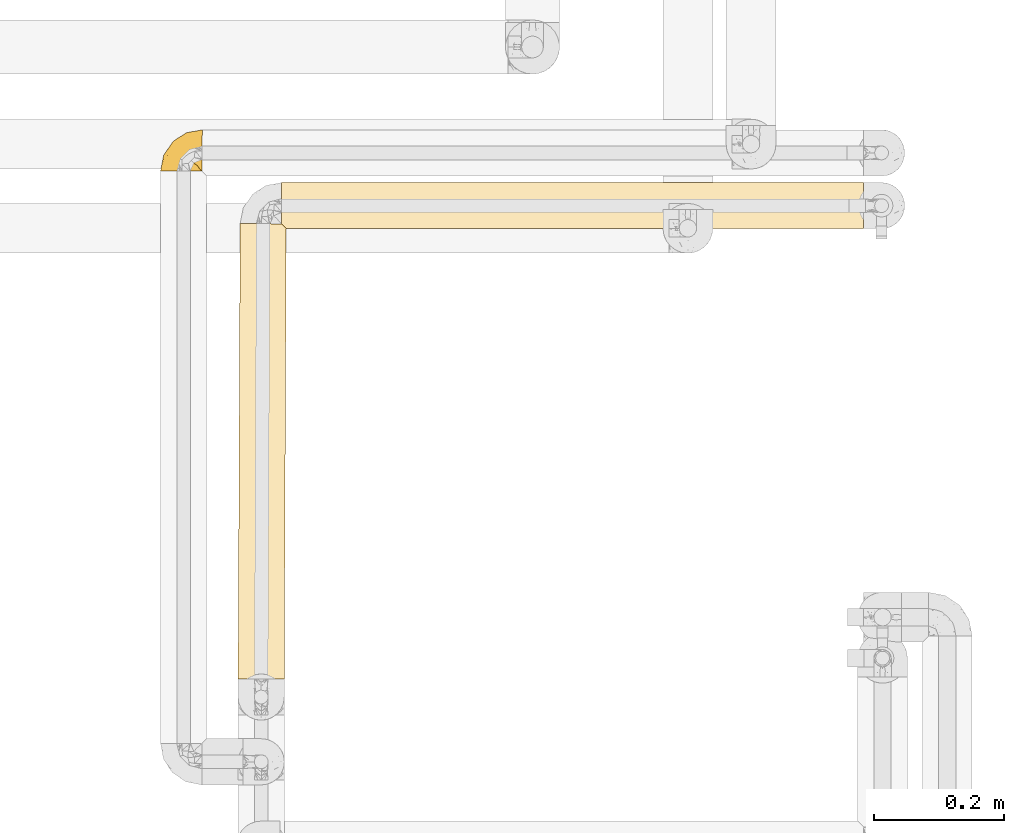
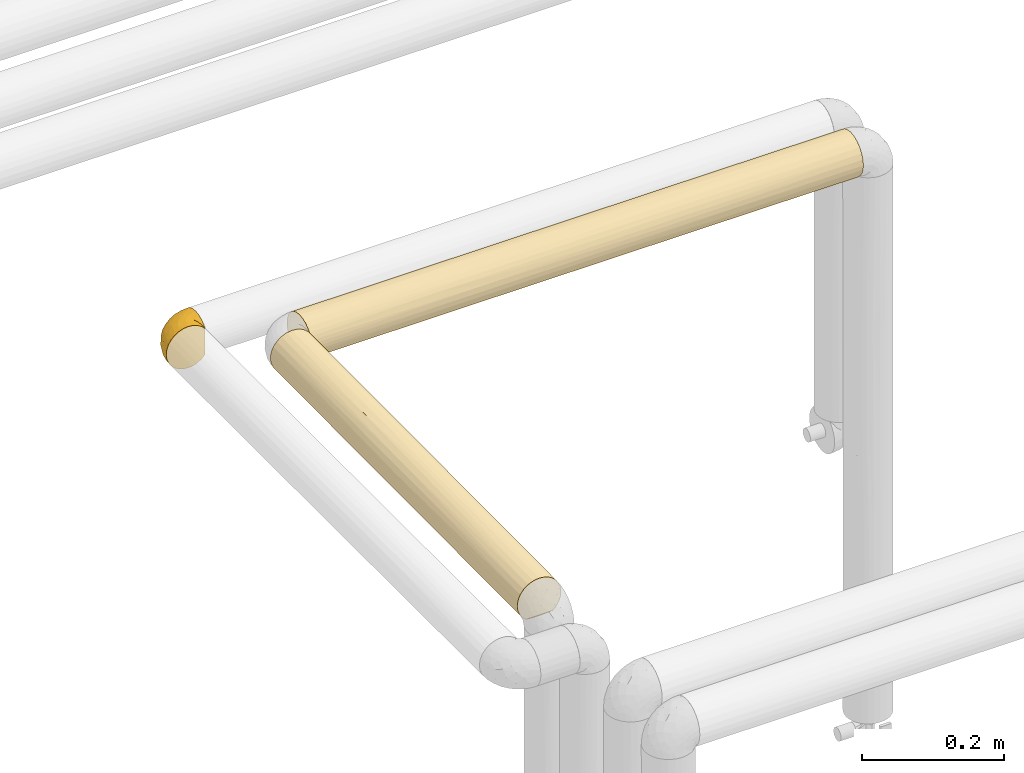
# One storey, part 88 of 827: 3 coverings.
"""IFC2X3 building model written with IfcOpenShell, lengths in millimetres."""

from ifc_helpers import new_model, entity, si_unit, converted_unit, derived_unit, direction, frame, origin, place, context, subcontext, project, spatial, faceted_brep, element, save


model = new_model("IFC2X3")

# Units and contexts
model_context = context("Model", 3, precision=0.01, world=origin(), true_north=direction((6.12303176911189e-17, 1.0)))
body_context = subcontext(model_context, "Body", "Model", "MODEL_VIEW")
ifc_project = project(units=[si_unit("LENGTHUNIT", "METRE", prefix="MILLI"), si_unit("AREAUNIT", "SQUARE_METRE"), si_unit("VOLUMEUNIT", "CUBIC_METRE"), converted_unit("PLANEANGLEUNIT", "DEGREE", entity("IfcRatioMeasure", 0.0174532925199433), si_unit("PLANEANGLEUNIT", "RADIAN"), dimensions=[0, 0, 0, 0, 0, 0, 0]), si_unit("MASSUNIT", "GRAM", prefix="KILO"), derived_unit("MASSDENSITYUNIT", [(si_unit("MASSUNIT", "GRAM", prefix="KILO"), 1), (si_unit("LENGTHUNIT", "METRE"), -3)]), derived_unit("MOMENTOFINERTIAUNIT", [(si_unit("LENGTHUNIT", "METRE"), 4)]), si_unit("TIMEUNIT", "SECOND"), si_unit("FREQUENCYUNIT", "HERTZ"), si_unit("THERMODYNAMICTEMPERATUREUNIT", "DEGREE_CELSIUS"), derived_unit("THERMALTRANSMITTANCEUNIT", [(si_unit("MASSUNIT", "GRAM", prefix="KILO"), 1), (si_unit("THERMODYNAMICTEMPERATUREUNIT", "KELVIN"), -1), (si_unit("TIMEUNIT", "SECOND"), -3)]), derived_unit("VOLUMETRICFLOWRATEUNIT", [(si_unit("LENGTHUNIT", "METRE"), 3), (si_unit("TIMEUNIT", "SECOND"), -1)]), derived_unit("MASSFLOWRATEUNIT", [(si_unit("MASSUNIT", "GRAM", prefix="KILO"), 1), (si_unit("TIMEUNIT", "SECOND"), -1)]), derived_unit("ROTATIONALFREQUENCYUNIT", [(si_unit("TIMEUNIT", "SECOND"), -1)]), si_unit("ELECTRICCURRENTUNIT", "AMPERE"), si_unit("ELECTRICVOLTAGEUNIT", "VOLT"), si_unit("POWERUNIT", "WATT"), si_unit("FORCEUNIT", "NEWTON", prefix="KILO"), si_unit("ILLUMINANCEUNIT", "LUX"), si_unit("LUMINOUSFLUXUNIT", "LUMEN"), si_unit("LUMINOUSINTENSITYUNIT", "CANDELA"), derived_unit("USERDEFINED", [(si_unit("MASSUNIT", "GRAM", prefix="KILO"), -1), (si_unit("LENGTHUNIT", "METRE"), -2), (si_unit("TIMEUNIT", "SECOND"), 3), (si_unit("LUMINOUSFLUXUNIT", "LUMEN"), 1)]), derived_unit("LINEARVELOCITYUNIT", [(si_unit("LENGTHUNIT", "METRE"), 1), (si_unit("TIMEUNIT", "SECOND"), -1)]), si_unit("PRESSUREUNIT", "PASCAL"), derived_unit("USERDEFINED", [(si_unit("LENGTHUNIT", "METRE"), -2), (si_unit("MASSUNIT", "GRAM", prefix="KILO"), 1), (si_unit("TIMEUNIT", "SECOND"), -2)]), derived_unit("LINEARFORCEUNIT", [(si_unit("MASSUNIT", "GRAM", prefix="KILO"), 1), (si_unit("LENGTHUNIT", "METRE"), 1), (si_unit("TIMEUNIT", "SECOND"), -2), (si_unit("LENGTHUNIT", "METRE"), -1)]), derived_unit("PLANARFORCEUNIT", [(si_unit("MASSUNIT", "GRAM", prefix="KILO"), 1), (si_unit("LENGTHUNIT", "METRE"), 1), (si_unit("TIMEUNIT", "SECOND"), -2), (si_unit("LENGTHUNIT", "METRE"), -2)])], contexts=[model_context])

# Site, building, storey
site_placement = place(None, origin())
site = spatial("IfcSite", under=ifc_project, at=site_placement, CompositionType="ELEMENT")
building_placement = place(site_placement, origin())
building = spatial("IfcBuilding", under=site, at=building_placement, CompositionType="ELEMENT")
storey_placement = place(building_placement, frame((0.0, 0.0, 28200.0)))
storey = spatial("IfcBuildingStorey", under=building, at=storey_placement, Name="08", CompositionType="ELEMENT", Elevation=28200.0)

# Coverings
covering_1_placement = place(storey_placement, frame((17769.65, 12906.85, 1862.75)))
element("IfcCovering", 1, at=covering_1_placement, inside=storey, Name=":ADSK_", ObjectType=":ADSK_", PredefinedType="INSULATION", context=body_context, shape_type="Brep", body=[
    faceted_brep([(65.02, 1.6, 59.59), (59.38, 1.6, 65.19), (52.64, 1.6, 69.4), (45.13, 1.6, 72.01), (37.25, 1.6, 72.9), (29.31, 1.6, 72.0), (21.77, 1.6, 69.36), (15.01, 1.6, 65.11), (9.37, 1.6, 59.47), (5.12, 1.6, 52.71), (2.49, 1.6, 45.17), (1.6, 1.6, 37.25), (2.49, 1.6, 29.31), (5.13, 1.6, 21.77), (9.38, 1.6, 15.01), (15.02, 1.6, 9.37), (21.78, 1.6, 5.12), (29.32, 1.6, 2.49), (37.25, 1.6, 1.6), (45.15, 1.6, 2.48), (52.65, 1.6, 5.1), (59.39, 1.6, 9.31), (65.02, 1.6, 14.9), (65.02, 1.6, 16.96), (65.02, 1.6, 18.43), (65.02, 1.6, 20.19), (65.02, 1.6, 21.96), (65.02, 1.6, 23.72), (65.02, 1.6, 25.49), (65.02, 1.6, 27.25), (65.02, 1.6, 29.02), (65.02, 1.6, 30.78), (65.02, 1.6, 32.55), (65.02, 1.6, 34.31), (65.02, 1.6, 36.08), (65.02, 1.6, 37.84), (65.02, 1.6, 39.61), (65.02, 1.6, 41.37), (65.02, 1.6, 43.14), (65.02, 1.6, 45.19), (65.02, 1.6, 47.25), (65.02, 1.6, 49.31), (65.02, 1.6, 51.36), (65.02, 1.6, 53.42), (65.02, 1.6, 55.48), (65.02, 1.6, 57.53), (65.25, 1.82, 14.9), (65.32, 7.46, 9.3), (65.41, 14.19, 5.09), (65.51, 21.7, 2.48), (65.61, 29.59, 1.6), (65.73, 38.82, 2.81), (65.84, 47.42, 6.37), (65.94, 54.8, 12.04), (66.01, 60.46, 19.42), (66.06, 64.03, 28.02), (66.07, 65.24, 37.25), (66.06, 64.03, 46.47), (66.01, 60.46, 55.07), (65.94, 54.8, 62.45), (65.84, 47.42, 68.12), (65.73, 38.82, 71.68), (65.61, 29.59, 72.9), (65.51, 21.7, 72.01), (65.41, 14.19, 69.4), (65.32, 7.46, 65.19), (65.25, 1.82, 59.59), (65.25, 1.82, 58.56), (65.25, 1.82, 56.8), (65.25, 1.82, 55.4), (65.25, 1.82, 54.0), (65.25, 1.82, 52.61), (65.25, 1.82, 51.21), (65.25, 1.82, 49.81), (65.25, 1.82, 48.42), (65.25, 1.82, 47.02), (65.25, 1.82, 45.62), (65.25, 1.82, 44.23), (65.25, 1.82, 42.83), (65.25, 1.82, 41.43), (65.25, 1.82, 40.04), (65.25, 1.82, 38.64), (65.25, 1.82, 37.25), (65.25, 1.82, 35.48), (65.25, 1.82, 33.72), (65.25, 1.82, 31.95), (65.25, 1.82, 30.19), (65.25, 1.82, 28.42), (65.25, 1.82, 26.66), (65.25, 1.82, 24.89), (65.25, 1.82, 23.13), (65.25, 1.82, 21.07), (65.25, 1.82, 19.01), (65.25, 1.82, 16.96), (65.08, 1.75, 50.34), (65.09, 1.76, 51.91), (65.09, 1.76, 27.74), (65.1, 1.76, 29.08), (65.08, 1.74, 23.04), (65.1, 1.76, 39.3), (65.09, 1.76, 16.3), (65.09, 1.75, 17.69), (65.09, 1.75, 42.08), (65.1, 1.76, 43.53), (65.08, 1.75, 58.23), (65.09, 1.75, 59.59), (65.08, 1.75, 46.32), (65.09, 1.76, 47.66), (65.08, 1.75, 19.01), (65.09, 1.75, 30.38), (65.08, 1.74, 31.67), (65.1, 1.76, 37.94), (65.09, 1.76, 36.56), (65.1, 1.76, 44.99), (65.08, 1.74, 35.16), (65.09, 1.75, 25.09), (65.08, 1.74, 26.37), (65.08, 1.75, 56.89), (65.09, 1.75, 40.66), (65.09, 1.75, 33.87), (65.1, 1.76, 20.36), (65.1, 1.76, 21.7), (65.1, 1.76, 53.38), (65.09, 1.75, 54.7), (65.09, 1.75, 14.9), (65.09, 1.76, 49.01), (53.81, 13.18, 3.58), (57.23, 8.23, 6.24), (51.46, 25.96, 1.6), (58.53, 27.78, 1.6), (41.06, 15.7, 1.6), (61.66, 5.23, 9.92), (46.26, 20.83, 1.6), (38.72, 7.06, 1.6), (12.96, 35.48, 27.55), (5.55, 16.98, 25.47), (6.52, 26.14, 37.25), (55.73, 35.76, 2.39), (58.52, 42.69, 4.31), (49.77, 40.26, 4.31), (22.23, 20.45, 7.06), (19.14, 10.53, 7.06), (13.73, 14.87, 12.03), (16.33, 36.12, 21.28), (24.07, 43.1, 18.72), (19.01, 33.59, 15.47), (11.96, 24.95, 18.27), (47.38, 62.05, 30.64), (50.03, 60.6, 23.6), (4.14, 14.28, 37.25), (55.87, 57.09, 15.54), (52.99, 49.76, 8.96), (39.13, 24.95, 2.3), (44.89, 27.82, 1.98), (32.43, 21.53, 3.14), (26.73, 11.52, 3.59), (8.12, 12.66, 18.27), (31.25, 33.84, 6.99), (39.9, 43.78, 8.59), (39.08, 32.38, 3.82), (22.62, 29.49, 9.95), (20.37, 44.33, 26.42), (39.22, 56.47, 23.12), (35.96, 57.13, 29.43), (43.84, 53.65, 15.54), (29.18, 51.22, 24.62), (25.55, 50.69, 31.18), (20.53, 46.89, 37.25), (13.53, 36.52, 37.25), (48.85, 32.93, 2.36), (53.35, 62.86, 37.25), (33.43, 47.48, 14.97), (27.33, 38.92, 12.03), (41.46, 60.63, 37.25), (31.0, 53.76, 37.25), (32.43, 21.54, 71.34), (39.08, 32.38, 70.67), (31.24, 33.83, 67.5), (47.38, 62.05, 43.85), (39.21, 56.46, 51.37), (50.03, 60.6, 50.89), (43.84, 53.65, 58.95), (55.87, 57.09, 58.95), (52.99, 49.76, 65.53), (25.55, 50.69, 43.31), (20.36, 44.32, 48.06), (29.17, 51.21, 49.86), (22.22, 20.45, 67.43), (19.13, 10.52, 67.43), (26.72, 11.52, 70.89), (33.41, 47.48, 59.51), (58.53, 27.78, 72.9), (55.73, 35.76, 72.1), (48.85, 32.93, 72.13), (38.72, 7.06, 72.9), (49.77, 40.26, 70.18), (58.52, 42.69, 70.18), (12.94, 35.46, 46.93), (5.54, 16.98, 49.01), (11.95, 24.95, 56.21), (8.12, 12.65, 56.21), (13.72, 14.87, 62.45), (51.46, 25.96, 72.9), (27.31, 38.92, 62.45), (19.0, 33.58, 59.01), (22.6, 29.48, 64.52), (41.06, 15.7, 72.9), (39.89, 43.78, 65.9), (24.06, 43.09, 55.76), (35.96, 57.13, 45.06), (39.14, 24.95, 72.2), (46.26, 20.83, 72.9), (16.32, 36.11, 53.2), (44.89, 27.82, 72.52), (53.81, 13.18, 70.91), (58.72, 9.7, 68.25), (61.66, 5.23, 64.57)], [[[0, 1, 2, 3, 4, 5, 6, 7, 8, 9, 10, 11, 12, 13, 14, 15, 16, 17, 18, 19, 20, 21, 22, 23, 24, 25, 26, 27, 28, 29, 30, 31, 32, 33, 34, 35, 36, 37, 38, 39, 40, 41, 42, 43, 44, 45]], [[46, 47, 48, 49, 50, 51, 52, 53, 54, 55, 56, 57, 58, 59, 60, 61, 62, 63, 64, 65, 66, 67, 68, 69, 70, 71, 72, 73, 74, 75, 76, 77, 78, 79, 80, 81, 82, 83, 84, 85, 86, 87, 88, 89, 90, 91, 92, 93]], [[94, 72, 95]], [[96, 87, 97]], [[26, 98, 27]], [[99, 81, 80]], [[100, 93, 101]], [[102, 103, 38]], [[104, 105, 0]], [[67, 105, 104]], [[106, 107, 40]], [[24, 101, 108]], [[109, 85, 110]], [[42, 94, 95]], [[81, 111, 82]], [[35, 34, 112]], [[23, 101, 24]], [[103, 113, 39]], [[30, 96, 97]], [[34, 114, 112]], [[115, 116, 28]], [[37, 102, 38]], [[68, 104, 117]], [[37, 118, 102]], [[119, 85, 84]], [[120, 91, 121]], [[29, 28, 116]], [[114, 33, 119]], [[122, 43, 95]], [[117, 123, 69]], [[67, 66, 105]], [[104, 45, 117]], [[122, 123, 43]], [[100, 23, 22]], [[100, 124, 46]], [[23, 100, 101]], [[75, 74, 107]], [[92, 108, 101]], [[116, 88, 96]], [[119, 84, 114]], [[101, 93, 92]], [[93, 100, 46]], [[22, 124, 100]], [[108, 25, 24]], [[120, 121, 25]], [[108, 92, 120]], [[25, 108, 120]], [[67, 104, 68]], [[45, 104, 0]], [[69, 68, 117]], [[117, 45, 44]], [[70, 123, 122]], [[123, 70, 69]], [[44, 123, 117]], [[123, 44, 43]], [[72, 71, 95]], [[71, 122, 95]], [[71, 70, 122]], [[125, 94, 41]], [[43, 42, 95]], [[107, 125, 41]], [[73, 72, 94]], [[94, 42, 41]], [[94, 125, 73]], [[74, 73, 125]], [[106, 76, 75]], [[76, 106, 113]], [[113, 106, 39]], [[107, 41, 40]], [[106, 40, 39]], [[125, 107, 74]], [[107, 106, 75]], [[78, 77, 103]], [[77, 113, 103]], [[77, 76, 113]], [[102, 78, 103]], [[39, 38, 103]], [[80, 79, 118]], [[102, 118, 79]], [[112, 111, 35]], [[118, 37, 36]], [[99, 111, 81]], [[112, 82, 111]], [[111, 99, 35]], [[36, 35, 99]], [[112, 83, 82]], [[83, 112, 114]], [[99, 118, 36]], [[118, 99, 80]], [[79, 78, 102]], [[83, 114, 84]], [[33, 114, 34]], [[109, 110, 31]], [[119, 33, 32]], [[119, 110, 85]], [[26, 25, 121]], [[31, 110, 32]], [[91, 120, 92]], [[88, 116, 115]], [[121, 91, 90]], [[90, 98, 121]], [[29, 116, 96]], [[115, 98, 89]], [[89, 88, 115]], [[29, 96, 30]], [[87, 96, 88]], [[31, 30, 109]], [[97, 87, 86]], [[90, 89, 98]], [[115, 28, 27]], [[32, 110, 119]], [[86, 85, 109]], [[109, 97, 86]], [[97, 109, 30]], [[121, 98, 26]], [[27, 98, 115]], [[48, 126, 49]], [[48, 47, 127]], [[49, 128, 129, 50]], [[128, 49, 126]], [[130, 126, 19]], [[46, 124, 131]], [[22, 21, 131]], [[126, 127, 20]], [[126, 130, 132, 128]], [[20, 19, 126]], [[19, 18, 133, 130]], [[46, 131, 47]], [[48, 127, 126]], [[47, 131, 127]], [[21, 127, 131]], [[124, 22, 131]], [[21, 20, 127]], [[134, 135, 136]], [[50, 129, 137]], [[138, 52, 51]], [[137, 139, 138]], [[140, 141, 142]], [[143, 144, 145]], [[133, 18, 17]], [[146, 135, 134]], [[147, 55, 148]], [[135, 12, 149]], [[150, 54, 53]], [[151, 53, 52]], [[54, 148, 55]], [[54, 150, 148]], [[151, 52, 138]], [[132, 152, 153]], [[154, 130, 155]], [[133, 17, 155]], [[14, 13, 156]], [[142, 15, 14]], [[155, 130, 133]], [[155, 17, 16]], [[141, 155, 16]], [[157, 158, 159]], [[155, 140, 154]], [[160, 146, 145]], [[160, 142, 146]], [[144, 143, 161]], [[147, 162, 163]], [[135, 13, 12]], [[136, 135, 149]], [[146, 156, 135]], [[164, 151, 158]], [[156, 142, 14]], [[165, 166, 163]], [[15, 141, 16]], [[158, 151, 139]], [[167, 134, 136, 168]], [[129, 169, 137]], [[150, 151, 164]], [[162, 165, 163]], [[55, 147, 170]], [[144, 171, 172]], [[153, 159, 169]], [[154, 140, 157]], [[154, 159, 152]], [[12, 11, 149]], [[135, 156, 13]], [[142, 156, 146]], [[142, 141, 15]], [[155, 141, 140]], [[159, 158, 139]], [[158, 172, 171]], [[169, 139, 137]], [[140, 160, 157]], [[170, 147, 173]], [[170, 56, 55]], [[166, 167, 174]], [[174, 173, 163]], [[147, 163, 173]], [[161, 166, 165]], [[174, 163, 166]], [[162, 147, 148]], [[144, 161, 165]], [[161, 134, 167]], [[165, 162, 171]], [[145, 144, 172]], [[148, 164, 162]], [[162, 164, 171]], [[171, 144, 165]], [[158, 171, 164]], [[160, 145, 172]], [[143, 146, 134]], [[157, 160, 172]], [[142, 160, 140]], [[158, 157, 172]], [[154, 157, 159]], [[146, 143, 145]], [[161, 143, 134]], [[151, 150, 53]], [[154, 152, 130]], [[148, 150, 164]], [[51, 50, 137]], [[151, 138, 139]], [[51, 137, 138]], [[169, 129, 128]], [[153, 128, 132]], [[159, 139, 169]], [[167, 166, 161]], [[130, 152, 132]], [[159, 153, 152]], [[128, 153, 169]], [[175, 176, 177]], [[173, 178, 170]], [[178, 179, 180]], [[180, 181, 182]], [[183, 60, 59]], [[184, 185, 186]], [[187, 188, 189]], [[179, 186, 190]], [[191, 192, 193]], [[5, 194, 189]], [[183, 195, 196]], [[5, 4, 194]], [[61, 196, 192]], [[196, 61, 60]], [[6, 5, 189]], [[58, 57, 180]], [[197, 136, 198]], [[182, 183, 59]], [[199, 200, 201]], [[7, 201, 8]], [[58, 182, 59]], [[198, 9, 200]], [[198, 149, 10]], [[7, 6, 188]], [[201, 200, 8]], [[193, 202, 191]], [[203, 204, 205]], [[187, 189, 175]], [[189, 206, 175]], [[9, 198, 10]], [[183, 207, 195]], [[188, 201, 7]], [[197, 198, 199]], [[201, 187, 205]], [[204, 203, 208]], [[9, 8, 200]], [[197, 167, 168, 136]], [[206, 189, 194]], [[61, 192, 62]], [[181, 190, 207]], [[57, 170, 178]], [[178, 209, 179]], [[173, 174, 209]], [[186, 185, 208]], [[210, 206, 211]], [[176, 195, 207]], [[149, 198, 136]], [[149, 11, 10]], [[198, 200, 199]], [[189, 188, 6]], [[201, 188, 187]], [[181, 207, 183]], [[205, 177, 203]], [[177, 207, 203]], [[175, 210, 176]], [[57, 56, 170]], [[184, 209, 174]], [[57, 178, 180]], [[185, 184, 167]], [[167, 184, 174]], [[209, 184, 186]], [[209, 186, 179]], [[209, 178, 173]], [[206, 210, 175]], [[204, 212, 199]], [[185, 197, 212]], [[190, 208, 203]], [[190, 186, 208]], [[181, 180, 179]], [[207, 190, 203]], [[179, 190, 181]], [[212, 204, 208]], [[199, 201, 205]], [[205, 204, 199]], [[187, 175, 177]], [[177, 205, 187]], [[207, 177, 176]], [[185, 212, 208]], [[199, 212, 197]], [[180, 182, 58]], [[183, 182, 181]], [[183, 196, 60]], [[213, 202, 193]], [[192, 196, 195]], [[192, 195, 193]], [[192, 191, 62]], [[195, 176, 193]], [[176, 210, 213]], [[167, 197, 185]], [[213, 210, 211]], [[202, 213, 211]], [[176, 213, 193]], [[63, 62, 191, 202]], [[64, 63, 214]], [[64, 214, 215]], [[65, 216, 66]], [[214, 202, 211, 206]], [[3, 206, 194, 4]], [[65, 215, 216]], [[2, 214, 3]], [[216, 105, 66]], [[1, 215, 2]], [[0, 105, 216]], [[65, 64, 215]], [[0, 216, 1]], [[214, 63, 202]], [[2, 215, 214]], [[206, 3, 214]], [[215, 1, 216]]]),
])
covering_2_placement = place(storey_placement, frame((17956.11, 12817.76, 1862.75)))
element("IfcCovering", 2, at=covering_2_placement, inside=storey, Name=":ADSK_", ObjectType=":ADSK_", PredefinedType="INSULATION", context=body_context, shape_type="Brep", body=[
    faceted_brep([(900.47, 71.99, 29.26), (900.47, 72.9, 37.25), (900.47, 71.68, 46.47), (900.47, 68.12, 55.07), (900.47, 62.45, 62.45), (900.47, 55.07, 68.12), (900.47, 46.47, 71.68), (900.47, 37.25, 72.9), (900.47, 28.02, 71.68), (900.47, 19.42, 68.12), (900.47, 12.04, 62.45), (900.47, 6.37, 55.07), (900.47, 2.81, 46.47), (900.47, 1.6, 37.25), (900.47, 2.5, 29.26), (900.47, 5.17, 21.68), (900.47, 9.47, 14.89), (900.47, 15.18, 9.25), (900.47, 59.31, 9.25), (900.47, 65.02, 14.89), (900.47, 69.32, 21.68), (1.6, 71.68, 28.02), (1.6, 68.12, 19.42), (1.6, 62.45, 12.04), (1.6, 55.07, 6.37), (1.6, 46.47, 2.81), (1.6, 37.25, 1.6), (1.6, 29.26, 2.5), (1.6, 21.68, 5.17), (1.6, 14.89, 9.47), (1.6, 9.25, 15.18), (1.6, 9.25, 59.31), (1.6, 14.89, 65.02), (1.6, 21.68, 69.32), (1.6, 29.26, 71.99), (1.6, 37.25, 72.9), (1.6, 46.47, 71.68), (1.6, 55.07, 68.12), (1.6, 62.45, 62.45), (1.6, 68.12, 55.07), (1.6, 71.68, 46.47), (1.6, 72.9, 37.25), (242.74, 7.59, 17.46), (7.25, 3.56, 25.57), (4.86, 5.97, 20.14), (893.31, 31.32, 2.09), (684.34, 37.25, 1.6), (892.82, 37.25, 1.6), (450.07, 17.34, 7.67), (682.64, 17.47, 7.58), (571.93, 9.9, 14.37), (894.78, 25.57, 3.56), (897.19, 20.14, 5.97), (307.74, 12.48, 11.6), (432.02, 4.74, 22.61), (247.58, 2.72, 28.35), (211.74, 18.17, 7.13), (286.4, 25.39, 3.62), (8.72, 2.09, 31.32), (489.61, 2.38, 29.79), (691.99, 1.6, 37.25), (663.32, 1.6, 37.25), (426.17, 1.6, 37.25), (217.69, 1.6, 37.25), (238.72, 37.25, 1.6), (672.65, 3.62, 25.39), (613.2, 28.33, 2.73), (9.21, 1.6, 37.25), (475.85, 37.25, 1.6), (710.26, 6.69, 18.88), (229.73, 57.61, 7.98), (296.9, 63.17, 12.78), (451.57, 57.15, 7.67), (613.2, 46.16, 2.73), (357.29, 44.06, 2.25), (450.16, 49.93, 3.93), (483.5, 72.9, 37.25), (363.03, 72.24, 30.45), (242.55, 72.9, 37.25), (587.74, 71.49, 27.35), (489.76, 67.36, 18.17), (259.14, 70.18, 23.6), (894.78, 48.92, 3.56), (893.31, 43.17, 2.09), (253.22, 50.89, 4.31), (197.08, 67.02, 17.63), (897.19, 54.35, 5.97), (683.41, 57.02, 7.58), (571.42, 62.58, 12.16), (691.98, 72.9, 37.25), (171.53, 72.36, 31.07), (711.49, 67.36, 18.17), (206.19, 65.53, 58.95), (286.67, 70.18, 50.89), (695.87, 65.53, 58.95), (635.57, 58.95, 65.53), (286.67, 58.95, 65.53), (237.69, 50.89, 70.18), (509.41, 50.89, 70.18), (615.39, 70.18, 50.89), (451.03, 65.53, 58.95), (363.03, 72.28, 43.83), (577.25, 72.27, 43.89), (314.32, 43.99, 72.25), (418.56, 37.25, 72.9), (532.49, 43.67, 72.31), (171.21, 72.36, 43.41), (667.75, 53.71, 68.86), (697.16, 47.96, 71.25), (210.08, 37.25, 72.9), (691.98, 37.25, 72.9), (659.51, 37.25, 72.9), (190.59, 18.17, 67.36), (256.09, 25.39, 70.87), (288.82, 2.73, 46.16), (544.75, 2.25, 44.06), (451.87, 3.93, 49.94), (577.28, 26.97, 71.38), (330.65, 12.16, 62.58), (8.72, 2.09, 43.17), (654.41, 19.48, 68.15), (412.34, 18.17, 67.36), (605.21, 12.78, 63.17), (218.64, 7.58, 57.02), (4.86, 5.97, 54.35), (672.29, 7.98, 57.61), (7.25, 3.56, 48.92), (450.49, 7.67, 57.15), (648.85, 4.31, 50.89)], [[[0, 1, 2, 3, 4, 5, 6, 7, 8, 9, 10, 11, 12, 13, 14, 15, 16, 17, 18, 19, 20]], [[21, 22, 23, 24, 25, 26, 27, 28, 29, 30, 31, 32, 33, 34, 35, 36, 37, 38, 39, 40, 41]], [[42, 43, 44]], [[45, 46, 47]], [[48, 49, 50]], [[49, 51, 52]], [[53, 30, 29]], [[42, 54, 55]], [[48, 56, 57]], [[55, 58, 43]], [[54, 42, 50]], [[59, 60, 61, 62]], [[63, 55, 62]], [[27, 64, 57]], [[65, 59, 54]], [[43, 42, 55]], [[29, 56, 53]], [[44, 30, 42]], [[17, 50, 49]], [[27, 57, 28]], [[50, 17, 16]], [[66, 49, 48]], [[66, 46, 45]], [[65, 15, 14]], [[52, 17, 49]], [[58, 63, 67]], [[68, 66, 57]], [[51, 66, 45]], [[28, 56, 29]], [[49, 66, 51]], [[55, 54, 59]], [[63, 58, 55]], [[65, 69, 15]], [[69, 16, 15]], [[42, 53, 50]], [[66, 48, 57]], [[14, 13, 60]], [[60, 65, 14]], [[69, 54, 50]], [[57, 56, 28]], [[53, 56, 48]], [[50, 53, 48]], [[53, 42, 30]], [[60, 59, 65]], [[55, 59, 62]], [[54, 69, 65]], [[16, 69, 50]], [[66, 68, 46]], [[64, 27, 26]], [[64, 68, 57]], [[70, 71, 72]], [[73, 74, 75]], [[74, 68, 64]], [[76, 77, 78]], [[79, 80, 81]], [[73, 82, 83]], [[84, 25, 24]], [[80, 85, 81]], [[70, 23, 71]], [[18, 86, 87]], [[82, 73, 87]], [[83, 46, 73]], [[77, 79, 81]], [[18, 88, 19]], [[85, 22, 81]], [[76, 89, 79]], [[41, 78, 90]], [[87, 72, 88]], [[20, 91, 79]], [[80, 88, 71]], [[22, 21, 81]], [[91, 20, 19]], [[75, 87, 73]], [[0, 89, 1]], [[0, 20, 79]], [[74, 25, 84]], [[87, 86, 82]], [[87, 88, 18]], [[85, 80, 71]], [[0, 79, 89]], [[25, 74, 64]], [[71, 88, 72]], [[88, 80, 91]], [[72, 84, 70]], [[23, 22, 85]], [[78, 77, 90]], [[74, 73, 68]], [[26, 25, 64]], [[74, 84, 75]], [[88, 91, 19]], [[79, 91, 80]], [[79, 77, 76]], [[90, 81, 21]], [[84, 72, 75]], [[87, 75, 72]], [[81, 90, 77]], [[41, 90, 21]], [[84, 24, 70]], [[23, 70, 24]], [[46, 83, 47]], [[46, 68, 73]], [[23, 85, 71]], [[92, 93, 39]], [[94, 95, 4]], [[95, 96, 97, 98]], [[94, 99, 93, 92, 100]], [[39, 93, 40]], [[101, 76, 78]], [[38, 92, 39]], [[2, 89, 102]], [[94, 4, 3]], [[3, 2, 99]], [[37, 96, 38]], [[96, 95, 94, 100, 92]], [[103, 104, 105]], [[106, 93, 101]], [[98, 107, 95]], [[108, 107, 98]], [[5, 4, 95]], [[36, 97, 37]], [[104, 103, 109]], [[110, 7, 6]], [[36, 35, 109]], [[76, 101, 102]], [[109, 103, 36]], [[97, 96, 37]], [[105, 108, 98]], [[99, 102, 101]], [[105, 98, 103]], [[40, 106, 41]], [[106, 101, 78]], [[99, 101, 93]], [[99, 2, 102]], [[89, 2, 1]], [[89, 76, 102]], [[98, 97, 103]], [[36, 103, 97]], [[105, 104, 111, 110]], [[108, 110, 6]], [[110, 108, 105]], [[5, 108, 6]], [[99, 94, 3]], [[96, 92, 38]], [[108, 5, 107]], [[5, 95, 107]], [[41, 106, 78]], [[93, 106, 40]], [[112, 113, 33]], [[114, 115, 116]], [[33, 32, 112]], [[104, 113, 117]], [[32, 31, 118]], [[119, 63, 114]], [[34, 113, 109]], [[8, 117, 120]], [[121, 118, 122]], [[121, 117, 113]], [[8, 111, 117]], [[118, 31, 123]], [[12, 115, 61]], [[31, 124, 123]], [[125, 10, 122]], [[34, 33, 113]], [[123, 126, 114]], [[114, 126, 119]], [[113, 104, 109]], [[116, 123, 114]], [[122, 127, 125]], [[123, 127, 118]], [[115, 62, 61]], [[128, 12, 11]], [[123, 124, 126]], [[122, 120, 121]], [[120, 122, 10]], [[109, 35, 34]], [[115, 12, 128]], [[122, 118, 127]], [[118, 121, 112]], [[127, 128, 125]], [[120, 10, 9]], [[115, 114, 62]], [[12, 61, 60, 13]], [[115, 128, 116]], [[118, 112, 32]], [[113, 112, 121]], [[8, 120, 9]], [[117, 121, 120]], [[128, 127, 116]], [[123, 116, 127]], [[128, 11, 125]], [[10, 125, 11]], [[63, 119, 67]], [[63, 62, 114]], [[8, 7, 110, 111]], [[111, 104, 117]], [[47, 83, 82, 86, 18, 17, 52, 51, 45]], [[30, 44, 43, 58, 67, 119, 126, 124, 31]]]),
])
covering_3_placement = place(storey_placement, frame((17889.35, 12122.51, 1862.75)))
element("IfcCovering", 3, at=covering_3_placement, inside=storey, Name=":ADSK_", ObjectType=":ADSK_", PredefinedType="INSULATION", context=body_context, shape_type="Brep", body=[
    faceted_brep([(6.37, 1.83, 55.07), (2.81, 1.85, 46.47), (1.6, 1.85, 37.25), (2.51, 1.85, 29.22), (5.21, 1.84, 21.61), (9.55, 1.82, 14.8), (15.3, 1.79, 9.15), (59.44, 1.6, 9.34), (65.09, 1.57, 14.99), (69.35, 1.55, 21.75), (72.0, 1.54, 29.29), (72.89, 1.54, 37.25), (71.68, 1.54, 46.47), (68.12, 1.56, 55.07), (62.45, 1.58, 62.45), (55.07, 1.61, 68.12), (46.47, 1.65, 71.68), (37.24, 1.69, 72.9), (28.02, 1.73, 71.68), (19.42, 1.77, 68.12), (12.04, 1.81, 62.45), (48.35, 704.58, 2.5), (40.36, 704.62, 1.6), (31.13, 704.66, 2.81), (22.53, 704.7, 6.37), (15.15, 704.73, 12.04), (9.48, 704.76, 19.42), (5.92, 704.77, 28.02), (4.71, 704.78, 37.25), (5.92, 704.77, 46.47), (9.48, 704.76, 55.07), (15.15, 704.73, 62.45), (22.53, 704.7, 68.12), (31.13, 704.66, 71.68), (40.36, 704.62, 72.9), (48.35, 704.58, 71.99), (55.92, 704.55, 69.32), (62.71, 704.52, 65.02), (68.36, 704.5, 59.31), (68.36, 704.5, 15.18), (62.71, 704.52, 9.47), (55.92, 704.55, 5.17), (4.46, 506.69, 30.59), (32.5, 480.73, 2.26), (39.12, 426.3, 1.6), (38.82, 356.98, 1.6), (4.32, 314.56, 27.55), (11.87, 521.43, 14.78), (8.7, 345.07, 18.08), (8.24, 518.98, 20.17), (17.63, 473.35, 8.96), (31.39, 8.85, 2.08), (30.9, 246.8, 2.38), (37.28, 9.34, 1.6), (2.52, 210.33, 37.25), (3.15, 353.31, 37.25), (3.44, 418.81, 37.25), (13.09, 329.63, 12.44), (20.25, 5.03, 5.91), (24.31, 358.47, 4.68), (25.67, 7.4, 3.54), (17.58, 236.82, 8.22), (38.2, 217.82, 1.6), (58.77, 353.76, 7.71), (64.39, 426.56, 12.09), (47.49, 289.87, 2.74), (49.02, 7.35, 3.59), (43.24, 8.84, 2.1), (63.43, 215.12, 12.07), (51.32, 504.31, 3.62), (68.41, 352.2, 17.4), (54.47, 4.91, 6.03), (75.05, 488.37, 37.25), (75.48, 697.34, 31.32), (75.97, 696.85, 37.25), (73.6, 417.24, 28.33), (71.78, 202.48, 25.45), (71.62, 701.22, 20.14), (74.02, 698.81, 25.57), (74.13, 279.89, 37.25), (74.43, 349.19, 37.25), (74.13, 458.64, 44.72), (73.22, 225.05, 44.1), (39.43, 496.14, 72.9), (63.63, 372.52, 62.91), (66.54, 231.16, 58.95), (68.25, 468.9, 58.07), (71.3, 348.25, 51.84), (71.62, 701.22, 54.35), (74.02, 698.81, 48.92), (60.34, 181.87, 65.06), (57.92, 361.37, 67.36), (54.9, 187.82, 68.67), (48.62, 391.86, 71.57), (39.09, 418.65, 72.9), (38.51, 287.66, 72.9), (75.48, 697.34, 43.17), (44.77, 199.42, 72.27), (38.17, 210.17, 72.9), (27.31, 485.29, 70.79), (24.72, 254.67, 70.18), (31.98, 314.44, 72.27), (17.1, 353.25, 65.53), (5.87, 353.3, 50.89), (10.08, 254.73, 58.95), (11.17, 499.83, 58.95), (4.29, 454.87, 44.2), (3.29, 229.03, 44.2)], [[[0, 1, 2, 3, 4, 5, 6, 7, 8, 9, 10, 11, 12, 13, 14, 15, 16, 17, 18, 19, 20]], [[21, 22, 23, 24, 25, 26, 27, 28, 29, 30, 31, 32, 33, 34, 35, 36, 37, 38, 39, 40, 41]], [[28, 27, 42]], [[43, 22, 44, 45]], [[46, 4, 3]], [[47, 26, 25]], [[47, 48, 49]], [[50, 25, 24]], [[51, 52, 53]], [[3, 2, 54]], [[46, 48, 4]], [[46, 54, 55, 56]], [[48, 5, 4]], [[42, 46, 56]], [[48, 57, 5]], [[26, 49, 27]], [[58, 59, 60]], [[5, 57, 61]], [[58, 61, 59]], [[52, 45, 62, 53]], [[61, 6, 5]], [[60, 59, 52]], [[54, 46, 3]], [[57, 50, 61]], [[24, 23, 59]], [[45, 52, 43]], [[58, 6, 61]], [[49, 26, 47]], [[50, 57, 47]], [[50, 24, 59]], [[47, 57, 48]], [[61, 50, 59]], [[50, 47, 25]], [[48, 46, 49]], [[49, 46, 42]], [[60, 52, 51]], [[43, 59, 23]], [[59, 43, 52]], [[22, 43, 23]], [[28, 42, 56]], [[49, 42, 27]], [[21, 44, 22]], [[63, 40, 64]], [[65, 66, 67]], [[7, 68, 8]], [[64, 68, 63]], [[41, 40, 63]], [[67, 62, 65]], [[65, 69, 63]], [[68, 70, 8]], [[71, 66, 65]], [[7, 71, 63]], [[39, 70, 64]], [[72, 73, 74]], [[70, 75, 76]], [[7, 63, 68]], [[39, 64, 40]], [[39, 77, 70]], [[77, 78, 75]], [[69, 44, 21]], [[41, 69, 21]], [[75, 78, 73]], [[76, 79, 10]], [[70, 9, 8]], [[10, 79, 11]], [[73, 72, 75]], [[79, 76, 75]], [[70, 76, 9]], [[10, 9, 76]], [[77, 75, 70]], [[63, 69, 41]], [[70, 68, 64]], [[44, 69, 65]], [[71, 65, 63]], [[62, 67, 53]], [[65, 62, 45, 44]], [[75, 72, 80, 79]], [[80, 81, 82]], [[35, 34, 83]], [[84, 85, 86]], [[82, 11, 79, 80]], [[13, 12, 87]], [[86, 88, 38]], [[89, 87, 81]], [[90, 91, 92]], [[93, 83, 94, 95]], [[81, 80, 72, 74]], [[88, 87, 89]], [[96, 81, 74]], [[13, 87, 85]], [[90, 84, 91]], [[91, 37, 36]], [[86, 38, 37]], [[97, 93, 95]], [[85, 84, 90]], [[88, 86, 87]], [[17, 16, 97]], [[83, 93, 35]], [[13, 85, 14]], [[93, 91, 36]], [[93, 36, 35]], [[90, 92, 15]], [[92, 16, 15]], [[86, 85, 87]], [[37, 91, 84]], [[37, 84, 86]], [[90, 15, 14]], [[85, 90, 14]], [[91, 93, 92]], [[92, 93, 97]], [[89, 81, 96]], [[82, 87, 12]], [[87, 82, 81]], [[11, 82, 12]], [[97, 95, 98, 17]], [[92, 97, 16]], [[99, 100, 101]], [[18, 101, 100]], [[99, 94, 33]], [[102, 19, 100]], [[100, 99, 102]], [[33, 94, 83, 34]], [[18, 17, 98]], [[31, 102, 32]], [[101, 98, 95, 94]], [[102, 20, 19]], [[19, 18, 100]], [[103, 104, 105]], [[33, 32, 99]], [[103, 30, 29]], [[103, 0, 104]], [[105, 102, 31]], [[106, 28, 56, 55, 54, 2, 107]], [[20, 102, 104]], [[30, 105, 31]], [[18, 98, 101]], [[0, 20, 104]], [[103, 107, 1]], [[0, 103, 1]], [[94, 99, 101]], [[107, 2, 1]], [[102, 99, 32]], [[103, 105, 30]], [[102, 105, 104]], [[106, 107, 103]], [[103, 29, 106]], [[28, 106, 29]], [[58, 60, 51, 53, 67, 66, 71, 7, 6]], [[38, 88, 89, 96, 74, 73, 78, 77, 39]]]),
])

save(model, "model.ifc")
